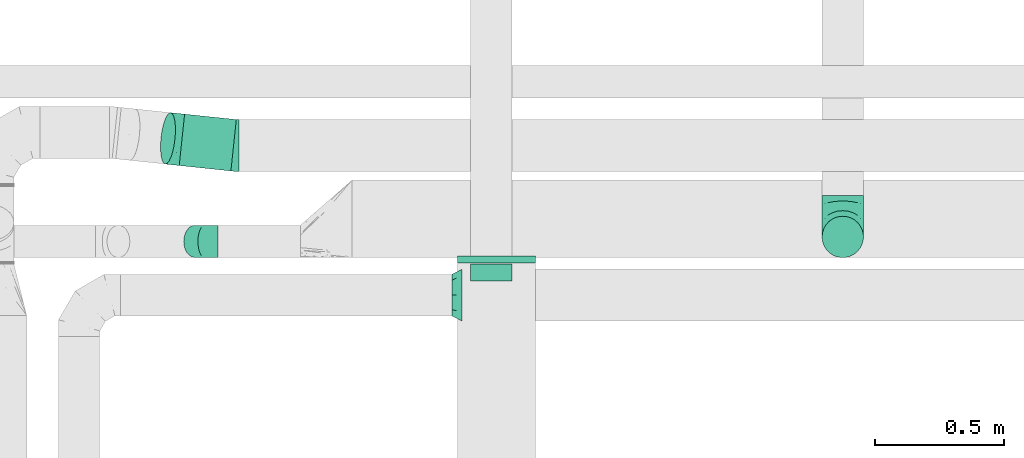
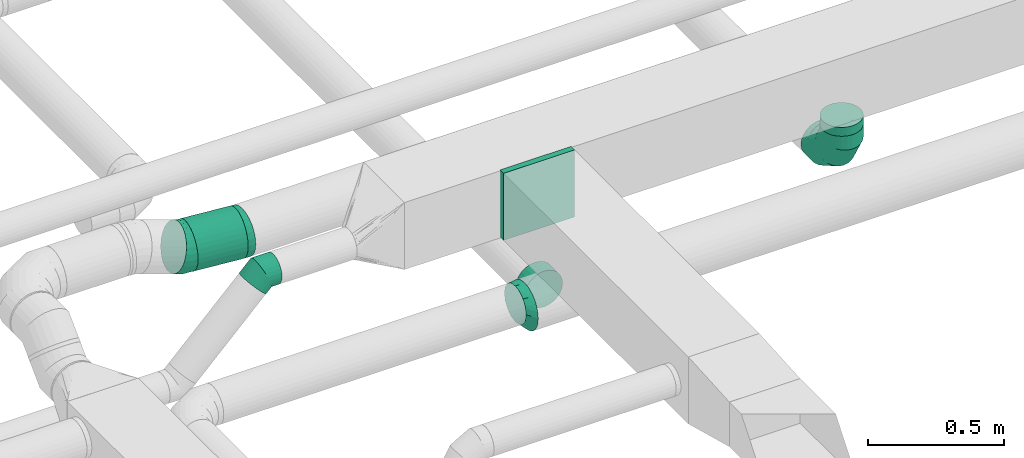
# One storey, part 16 of 60: 7 flow fittings, 2 flow segments.
"""IFC2X3 building model written with IfcOpenShell, lengths in millimetres."""

from ifc_helpers import new_model, entity, si_unit, converted_unit, derived_unit, direction, frame, origin, origin_2d_with_axis, place, context, subcontext, project, spatial, rectangle, circle, extrude, faceted_brep, source, transform, mapped, material, type_object, type_shapes, element, save


model = new_model("IFC2X3")

# Units and contexts
model_context = context("Model", 3, precision=0.01, world=origin(), true_north=direction((6.12303176911189e-17, 1.0)))
body_context = subcontext(model_context, "Body", "Model", "MODEL_VIEW")
ifc_project = project(units=[si_unit("LENGTHUNIT", "METRE", prefix="MILLI"), si_unit("AREAUNIT", "SQUARE_METRE"), si_unit("VOLUMEUNIT", "CUBIC_METRE"), converted_unit("PLANEANGLEUNIT", "DEGREE", entity("IfcRatioMeasure", 0.0174532925199433), si_unit("PLANEANGLEUNIT", "RADIAN"), dimensions=[0, 0, 0, 0, 0, 0, 0]), si_unit("MASSUNIT", "GRAM", prefix="KILO"), derived_unit("MASSDENSITYUNIT", [(si_unit("MASSUNIT", "GRAM", prefix="KILO"), 1), (si_unit("LENGTHUNIT", "METRE"), -3)]), derived_unit("MOMENTOFINERTIAUNIT", [(si_unit("LENGTHUNIT", "METRE"), 4)]), si_unit("TIMEUNIT", "SECOND"), si_unit("FREQUENCYUNIT", "HERTZ"), si_unit("THERMODYNAMICTEMPERATUREUNIT", "DEGREE_CELSIUS"), derived_unit("THERMALTRANSMITTANCEUNIT", [(si_unit("MASSUNIT", "GRAM", prefix="KILO"), 1), (si_unit("THERMODYNAMICTEMPERATUREUNIT", "KELVIN"), -1), (si_unit("TIMEUNIT", "SECOND"), -3)]), derived_unit("VOLUMETRICFLOWRATEUNIT", [(si_unit("LENGTHUNIT", "METRE"), 3), (si_unit("TIMEUNIT", "SECOND"), -1)]), derived_unit("MASSFLOWRATEUNIT", [(si_unit("MASSUNIT", "GRAM", prefix="KILO"), 1), (si_unit("TIMEUNIT", "SECOND"), -1)]), derived_unit("ROTATIONALFREQUENCYUNIT", [(si_unit("TIMEUNIT", "SECOND"), -1)]), si_unit("ELECTRICCURRENTUNIT", "AMPERE"), si_unit("ELECTRICVOLTAGEUNIT", "VOLT"), si_unit("POWERUNIT", "WATT"), si_unit("FORCEUNIT", "NEWTON", prefix="KILO"), si_unit("ILLUMINANCEUNIT", "LUX"), si_unit("LUMINOUSFLUXUNIT", "LUMEN"), si_unit("LUMINOUSINTENSITYUNIT", "CANDELA"), derived_unit("USERDEFINED", [(si_unit("MASSUNIT", "GRAM", prefix="KILO"), -1), (si_unit("LENGTHUNIT", "METRE"), -2), (si_unit("TIMEUNIT", "SECOND"), 3), (si_unit("LUMINOUSFLUXUNIT", "LUMEN"), 1)]), derived_unit("LINEARVELOCITYUNIT", [(si_unit("LENGTHUNIT", "METRE"), 1), (si_unit("TIMEUNIT", "SECOND"), -1)]), si_unit("PRESSUREUNIT", "PASCAL"), derived_unit("USERDEFINED", [(si_unit("LENGTHUNIT", "METRE"), -2), (si_unit("MASSUNIT", "GRAM", prefix="KILO"), 1), (si_unit("TIMEUNIT", "SECOND"), -2)]), derived_unit("LINEARFORCEUNIT", [(si_unit("MASSUNIT", "GRAM", prefix="KILO"), 1), (si_unit("LENGTHUNIT", "METRE"), 1), (si_unit("TIMEUNIT", "SECOND"), -2), (si_unit("LENGTHUNIT", "METRE"), -1)]), derived_unit("PLANARFORCEUNIT", [(si_unit("MASSUNIT", "GRAM", prefix="KILO"), 1), (si_unit("LENGTHUNIT", "METRE"), 1), (si_unit("TIMEUNIT", "SECOND"), -2), (si_unit("LENGTHUNIT", "METRE"), -2)])], contexts=[model_context])

# Site, building, storey
site_placement = place(None, origin())
site = spatial("IfcSite", under=ifc_project, at=site_placement, CompositionType="ELEMENT")
building_placement = place(site_placement, origin())
building = spatial("IfcBuilding", under=site, at=building_placement, CompositionType="ELEMENT")
storey_placement = place(building_placement, frame((0.0, 0.0, 19800.0)))
storey = spatial("IfcBuildingStorey", under=building, at=storey_placement, CompositionType="ELEMENT", Elevation=19800.0)

# Flow segments
duct_segment_type = type_object("IfcDuctSegmentType", PredefinedType="NOTDEFINED")
flow_segment_1_placement = place(storey_placement, frame((17387.86, 9978.45, 3383.4)))
element("IfcFlowSegment", 1, at=flow_segment_1_placement, inside=storey, type_object=duct_segment_type, context=body_context, shape_type="SweptSolid", body=[
    extrude(circle(Radius=100.0, at=origin_2d_with_axis()), frame((12.05, 122.07, 101.6), z_axis=(0.994516576413521, -0.104579057362021, 0.0), x_axis=(0.104579057362021, 0.994516576413521, 0.0)), (0.0, 0.0, 1.0), 200.979366839111),
])
flow_segment_2_placement = place(storey_placement, frame((19873.44, 9643.57, 3359.92)))
element("IfcFlowSegment", 2, at=flow_segment_2_placement, inside=storey, type_object=duct_segment_type, context=body_context, shape_type="SweptSolid", body=[
    extrude(circle(Radius=80.0, at=origin_2d_with_axis()), frame((81.6, 81.6, 0.0), z_axis=(0.0, 0.0, 1.0), x_axis=(-1.0, 0.0, 0.0)), (0.0, 0.0, 1.0), 40.0764985282212),
])

# Flow fittings
ifc_material = material()
duct_fitting_type_1 = type_object("IfcDuctFittingType", PredefinedType="NOTDEFINED", material=ifc_material)
shared_shape_1 = source(origin(), body_context, "Body", "SweptSolid", [
    extrude(rectangle(XDim=26.0960000000005, YDim=300.0, at=origin_2d_with_axis()), frame((6.95, 0.0, -150.0)), (0.0, 0.0, 1.0), 300.0),
])
type_shapes(duct_fitting_type_1, [shared_shape_1])
flow_fitting_1_placement = place(storey_placement, frame((18616.2, 9645.16, 3570.0), z_axis=(0.0, 0.0, -1.0), x_axis=(0.0, -1.0, 0.0)))
element("IfcFlowFitting", 3, at=flow_fitting_1_placement, inside=storey, type_object=duct_fitting_type_1, material=ifc_material, context=body_context, shape_type="MappedRepresentation", body=[
    mapped(shared_shape_1, transform((0.0, 0.0, 0.0), scale=1.0)),
])
duct_fitting_type_2 = type_object("IfcDuctFittingType", PredefinedType="NOTDEFINED", material=ifc_material)
shared_shape_2 = source(origin(), body_context, "Body", "Brep", [
    faceted_brep([(-160.0, 0.0, -80.0), (-160.0, -20.71, -77.27), (-160.0, -40.0, -69.28), (-160.0, -56.57, -56.57), (-160.0, -69.28, -40.0), (-160.0, -77.27, -20.71), (-160.0, -80.0, 0.0), (-160.0, -77.27, 20.71), (-160.0, -69.28, 40.0), (-160.0, -56.57, 56.57), (-160.0, -40.0, 69.28), (-160.0, -20.71, 77.27), (-160.0, 0.0, 80.0), (-160.0, 20.71, 77.27), (-160.0, 40.0, 69.28), (-160.0, 56.57, 56.57), (-160.0, 69.28, 40.0), (-160.0, 77.27, 20.71), (-160.0, 80.0, 0.0), (-160.0, 77.27, -20.71), (-160.0, 69.28, -40.0), (-160.0, 56.57, -56.57), (-160.0, 40.0, -69.28), (-160.0, 20.71, -77.27), (-122.68, 20.71, 77.27), (-127.85, 40.0, 69.28), (-117.13, 0.0, 80.0), (-132.29, 56.57, 56.57), (-137.83, 77.27, 20.71), (-138.56, 80.0, 0.0), (-135.69, 69.28, 40.0), (-135.69, 69.28, -40.0), (-132.29, 56.57, -56.57), (-137.83, 77.27, -20.71), (-122.68, 20.71, -77.27), (-117.13, 0.0, -80.0), (-127.85, 40.0, -69.28), (-111.58, -20.71, -77.27), (-106.41, -40.0, -69.28), (-101.97, -56.57, -56.57), (-98.56, -69.28, -40.0), (-96.42, -77.27, -20.71), (-95.69, -80.0, 0.0), (-96.42, -77.27, 20.71), (-98.56, -69.28, 40.0), (-101.97, -56.57, 56.57), (-106.41, -40.0, 69.28), (-111.58, -20.71, 77.27), (-58.03, 58.03, 77.27), (-72.15, 72.15, 69.28), (-42.87, 42.87, 80.0), (-84.28, 84.28, 56.57), (-93.59, 93.59, 40.0), (-99.44, 99.44, 20.71), (-101.44, 101.44, 0.0), (-99.44, 99.44, -20.71), (-93.59, 93.59, -40.0), (-84.28, 84.28, -56.57), (-58.03, 58.03, -77.27), (-42.87, 42.87, -80.0), (-72.15, 72.15, -69.28), (-27.71, 27.71, -77.27), (-13.59, 13.59, -69.28), (-1.46, 1.46, -56.57), (7.85, -7.85, -40.0), (13.7, -13.7, -20.71), (15.69, -15.69, 0.0), (13.7, -13.7, 20.71), (7.85, -7.85, 40.0), (-1.46, 1.46, 56.57), (-13.59, 13.59, 69.28), (-27.71, 27.71, 77.27), (-20.71, 122.68, 77.27), (-40.0, 127.85, 69.28), (0.0, 117.13, 80.0), (-56.57, 132.29, 56.57), (-69.28, 135.69, 40.0), (-77.27, 137.83, 20.71), (-80.0, 138.56, 0.0), (-77.27, 137.83, -20.71), (-69.28, 135.69, -40.0), (-56.57, 132.29, -56.57), (-20.71, 122.68, -77.27), (0.0, 117.13, -80.0), (-40.0, 127.85, -69.28), (20.71, 111.58, -77.27), (40.0, 106.41, -69.28), (56.57, 101.97, -56.57), (69.28, 98.56, -40.0), (77.27, 96.42, -20.71), (80.0, 95.69, 0.0), (77.27, 96.42, 20.71), (69.28, 98.56, 40.0), (56.57, 101.97, 56.57), (40.0, 106.41, 69.28), (20.71, 111.58, 77.27), (-20.71, 160.0, -77.27), (-40.0, 160.0, -69.28), (-56.57, 160.0, -56.57), (-69.28, 160.0, -40.0), (-77.27, 160.0, -20.71), (-80.0, 160.0, 0.0), (-77.27, 160.0, 20.71), (-69.28, 160.0, 40.0), (-56.57, 160.0, 56.57), (-40.0, 160.0, 69.28), (-20.71, 160.0, 77.27), (0.0, 160.0, 80.0), (20.71, 160.0, 77.27), (40.0, 160.0, 69.28), (56.57, 160.0, 56.57), (69.28, 160.0, 40.0), (77.27, 160.0, 20.71), (80.0, 160.0, 0.0), (77.27, 160.0, -20.71), (69.28, 160.0, -40.0), (56.57, 160.0, -56.57), (40.0, 160.0, -69.28), (20.71, 160.0, -77.27), (0.0, 160.0, -80.0)], [[[0, 1, 2, 3, 4, 5, 6, 7, 8, 9, 10, 11, 12, 13, 14, 15, 16, 17, 18, 19, 20, 21, 22, 23]], [[24, 25, 14, 13]], [[26, 24, 13, 12]], [[14, 25, 27, 15]], [[28, 29, 18, 17]], [[30, 28, 17, 16]], [[15, 27, 30, 16]], [[20, 31, 32, 21]], [[33, 31, 20, 19]], [[18, 29, 33, 19]], [[34, 35, 0, 23]], [[36, 34, 23, 22]], [[32, 36, 22, 21]], [[1, 0, 35, 37]], [[2, 1, 37, 38]], [[3, 2, 38, 39]], [[5, 4, 40, 41]], [[6, 5, 41, 42]], [[39, 40, 4, 3]], [[6, 42, 43, 7]], [[7, 43, 44, 8]], [[8, 44, 45, 9]], [[9, 45, 46, 10]], [[10, 46, 47, 11]], [[26, 12, 11, 47]], [[48, 49, 25, 24]], [[50, 48, 24, 26]], [[27, 25, 49, 51]], [[52, 53, 28, 30]], [[51, 52, 30, 27]], [[29, 28, 53, 54]], [[55, 56, 31, 33]], [[54, 55, 33, 29]], [[32, 31, 56, 57]], [[58, 59, 35, 34]], [[60, 58, 34, 36]], [[57, 60, 36, 32]], [[37, 35, 59, 61]], [[38, 37, 61, 62]], [[39, 38, 62, 63]], [[41, 40, 64, 65]], [[42, 41, 65, 66]], [[63, 64, 40, 39]], [[43, 42, 66, 67]], [[44, 43, 67, 68]], [[68, 69, 45, 44]], [[46, 45, 69, 70]], [[47, 46, 70, 71]], [[26, 47, 71, 50]], [[72, 73, 49, 48]], [[74, 72, 48, 50]], [[51, 49, 73, 75]], [[76, 77, 53, 52]], [[75, 76, 52, 51]], [[54, 53, 77, 78]], [[79, 80, 56, 55]], [[78, 79, 55, 54]], [[57, 56, 80, 81]], [[82, 83, 59, 58]], [[84, 82, 58, 60]], [[81, 84, 60, 57]], [[61, 59, 83, 85]], [[62, 61, 85, 86]], [[63, 62, 86, 87]], [[65, 64, 88, 89]], [[66, 65, 89, 90]], [[87, 88, 64, 63]], [[67, 66, 90, 91]], [[68, 67, 91, 92]], [[92, 93, 69, 68]], [[70, 69, 93, 94]], [[71, 70, 94, 95]], [[50, 71, 95, 74]], [[96, 97, 98, 99, 100, 101, 102, 103, 104, 105, 106, 107, 108, 109, 110, 111, 112, 113, 114, 115, 116, 117, 118, 119]], [[72, 74, 107, 106]], [[73, 72, 106, 105]], [[75, 73, 105, 104]], [[77, 76, 103, 102]], [[78, 77, 102, 101]], [[75, 104, 103, 76]], [[78, 101, 100, 79]], [[79, 100, 99, 80]], [[80, 99, 98, 81]], [[84, 97, 96, 82]], [[82, 96, 119, 83]], [[84, 81, 98, 97]], [[118, 117, 86, 85]], [[119, 118, 85, 83]], [[116, 87, 86, 117]], [[88, 115, 114, 89]], [[89, 114, 113, 90]], [[115, 88, 87, 116]], [[112, 111, 92, 91]], [[113, 112, 91, 90]], [[111, 110, 93, 92]], [[95, 94, 109, 108]], [[74, 95, 108, 107]], [[110, 109, 94, 93]]]),
])
type_shapes(duct_fitting_type_2, [shared_shape_2])
flow_fitting_2_placement = place(storey_placement, frame((19955.04, 9725.16, 3199.92), z_axis=(-1.0, 0.0, 0.0), x_axis=(0.0, -1.0, 0.0)))
element("IfcFlowFitting", 4, at=flow_fitting_2_placement, inside=storey, type_object=duct_fitting_type_2, material=ifc_material, context=body_context, shape_type="MappedRepresentation", body=[
    mapped(shared_shape_2, transform((0.0, 0.0, 0.0), scale=1.0)),
])
duct_fitting_type_3 = type_object("IfcDuctFittingType", PredefinedType="NOTDEFINED", material=ifc_material)
shared_shape_3 = source(origin(), body_context, "Body", "Brep", [
    faceted_brep([(-51.78, 0.0, -62.5), (-51.78, -16.18, -60.37), (-51.78, -31.25, -54.13), (-51.78, -44.19, -44.19), (-51.78, -54.13, -31.25), (-51.78, -60.37, -16.18), (-51.78, -62.5, 0.0), (-51.78, -60.37, 16.18), (-51.78, -54.13, 31.25), (-51.78, -44.19, 44.19), (-51.78, -31.25, 54.13), (-51.78, -16.18, 60.37), (-51.78, 0.0, 62.5), (-51.78, 16.18, 60.37), (-51.78, 31.25, 54.13), (-51.78, 44.19, 44.19), (-51.78, 54.13, 31.25), (-51.78, 60.37, 16.18), (-51.78, 62.5, 0.0), (-51.78, 60.37, -16.18), (-51.78, 54.13, -31.25), (-51.78, 44.19, -44.19), (-51.78, 31.25, -54.13), (-51.78, 16.18, -60.37), (-6.7, 16.18, 60.37), (-12.94, 31.25, 54.13), (0.0, 0.0, 62.5), (-18.31, 44.19, 44.19), (-22.42, 54.13, 31.25), (-25.01, 60.37, 16.18), (-25.89, 62.5, 0.0), (-25.01, 60.37, -16.18), (-22.42, 54.13, -31.25), (-18.31, 44.19, -44.19), (-6.7, 16.18, -60.37), (0.0, 0.0, -62.5), (-12.94, 31.25, -54.13), (6.7, -16.18, -60.37), (12.94, -31.25, -54.13), (18.31, -44.19, -44.19), (22.42, -54.13, -31.25), (25.01, -60.37, -16.18), (25.89, -62.5, 0.0), (25.01, -60.37, 16.18), (22.42, -54.13, 31.25), (18.31, -44.19, 44.19), (12.94, -31.25, 54.13), (6.7, -16.18, 60.37), (25.17, 48.05, 60.37), (14.51, 58.71, 54.13), (36.61, 36.61, 62.5), (5.36, 67.86, 44.19), (-1.66, 74.88, 31.25), (-6.08, 79.3, 16.18), (-7.58, 80.81, 0.0), (-6.08, 79.3, -16.18), (-1.66, 74.88, -31.25), (5.36, 67.86, -44.19), (14.51, 58.71, -54.13), (25.17, 48.05, -60.37), (36.61, 36.61, -62.5), (48.05, 25.17, -60.37), (58.71, 14.51, -54.13), (67.86, 5.36, -44.19), (74.88, -1.66, -31.25), (79.3, -6.08, -16.18), (80.81, -7.58, 0.0), (79.3, -6.08, 16.18), (74.88, -1.66, 31.25), (67.86, 5.36, 44.19), (58.71, 14.51, 54.13), (48.05, 25.17, 60.37)], [[[0, 1, 2, 3, 4, 5, 6, 7, 8, 9, 10, 11, 12, 13, 14, 15, 16, 17, 18, 19, 20, 21, 22, 23]], [[24, 25, 14, 13]], [[26, 24, 13, 12]], [[27, 15, 14, 25]], [[28, 29, 17, 16]], [[28, 16, 15, 27]], [[30, 18, 17, 29]], [[31, 32, 20, 19]], [[30, 31, 19, 18]], [[21, 20, 32, 33]], [[34, 35, 0, 23]], [[36, 34, 23, 22]], [[33, 36, 22, 21]], [[1, 0, 35, 37]], [[2, 1, 37, 38]], [[38, 39, 3, 2]], [[5, 4, 40, 41]], [[6, 5, 41, 42]], [[39, 40, 4, 3]], [[6, 42, 43, 7]], [[7, 43, 44, 8]], [[8, 44, 45, 9]], [[9, 45, 46, 10]], [[10, 46, 47, 11]], [[26, 12, 11, 47]], [[48, 49, 25, 24]], [[50, 48, 24, 26]], [[27, 25, 49, 51]], [[29, 28, 52, 53]], [[30, 29, 53, 54]], [[51, 52, 28, 27]], [[30, 54, 55, 31]], [[31, 55, 56, 32]], [[57, 33, 32, 56]], [[36, 58, 59, 34]], [[34, 59, 60, 35]], [[58, 36, 33, 57]], [[35, 60, 61, 37]], [[37, 61, 62, 38]], [[63, 39, 38, 62]], [[40, 64, 65, 41]], [[41, 65, 66, 42]], [[64, 40, 39, 63]], [[43, 42, 66, 67]], [[44, 43, 67, 68]], [[68, 69, 45, 44]], [[47, 46, 70, 71]], [[26, 47, 71, 50]], [[69, 70, 46, 45]], [[59, 58, 57, 56, 55, 54, 53, 52, 51, 49, 48, 50, 71, 70, 69, 68, 67, 66, 65, 64, 63, 62, 61, 60]]]),
])
type_shapes(duct_fitting_type_3, [shared_shape_3])
flow_fitting_3_placement = place(storey_placement, frame((17487.7, 9707.66, 3569.92), z_axis=(0.0, 1.0, 0.0), x_axis=(0.707106781186554, 0.0, 0.707106781186541)))
element("IfcFlowFitting", 5, at=flow_fitting_3_placement, inside=storey, type_object=duct_fitting_type_3, material=ifc_material, context=body_context, shape_type="MappedRepresentation", body=[
    mapped(shared_shape_3, transform((0.0, 0.0, 0.0), scale=1.0)),
])
duct_fitting_type_4 = type_object("IfcDuctFittingType", PredefinedType="NOTDEFINED", material=ifc_material)
shared_shape_4 = source(origin(), body_context, "Body", "Brep", [
    faceted_brep([(20.0, 0.0, -80.0), (20.0, 20.71, -77.27), (20.0, 40.0, -69.28), (20.0, 56.57, -56.57), (20.0, 69.28, -40.0), (20.0, 77.27, -20.71), (20.0, 80.0, 0.0), (20.0, 77.27, 20.71), (20.0, 69.28, 40.0), (20.0, 56.57, 56.57), (20.0, 40.0, 69.28), (20.0, 20.71, 77.27), (20.0, 0.0, 80.0), (20.0, -20.71, 77.27), (20.0, -40.0, 69.28), (20.0, -56.57, 56.57), (20.0, -69.28, 40.0), (20.0, -77.27, 20.71), (20.0, -80.0, 0.0), (20.0, -77.27, -20.71), (20.0, -69.28, -40.0), (20.0, -56.57, -56.57), (20.0, -40.0, -69.28), (20.0, -20.71, -77.27), (0.0, 0.0, 80.0), (-46.1, 0.0, 80.0), (-46.1, -20.71, 77.27), (0.0, -20.71, 77.27), (-46.1, -40.0, 69.28), (0.0, -40.0, 69.28), (0.0, -56.57, 56.57), (-46.1, -56.57, 56.57), (0.0, -69.28, 40.0), (-46.1, -69.28, 40.0), (-46.1, -77.27, 20.71), (0.0, -77.27, 20.71), (-46.1, -80.0, 0.0), (0.0, -80.0, 0.0), (-46.1, -77.27, -20.71), (0.0, -77.27, -20.71), (-46.1, -69.28, -40.0), (0.0, -69.28, -40.0), (0.0, -56.57, -56.57), (-46.1, -56.57, -56.57), (0.0, -40.0, -69.28), (-46.1, -40.0, -69.28), (-46.1, -20.71, -77.27), (0.0, -20.71, -77.27), (-46.1, 0.0, -80.0), (0.0, 0.0, -80.0), (-46.1, 20.71, -77.27), (0.0, 20.71, -77.27), (-46.1, 40.0, -69.28), (0.0, 40.0, -69.28), (0.0, 56.57, -56.57), (-46.1, 56.57, -56.57), (0.0, 69.28, -40.0), (-46.1, 69.28, -40.0), (-46.1, 77.27, -20.71), (0.0, 77.27, -20.71), (-46.1, 80.0, 0.0), (0.0, 80.0, 0.0), (-46.1, 77.27, 20.71), (0.0, 77.27, 20.71), (-46.1, 69.28, 40.0), (0.0, 69.28, 40.0), (0.0, 56.57, 56.57), (-46.1, 56.57, 56.57), (0.0, 40.0, 69.28), (-46.1, 40.0, 69.28), (-46.1, 20.71, 77.27), (0.0, 20.71, 77.27)], [[[0, 1, 2, 3, 4, 5, 6, 7, 8, 9, 10, 11, 12, 13, 14, 15, 16, 17, 18, 19, 20, 21, 22, 23]], [[13, 12, 24, 25, 26, 27]], [[14, 13, 27, 26, 28, 29]], [[30, 15, 14, 29, 28, 31]], [[17, 16, 32, 33, 34, 35]], [[18, 17, 35, 34, 36, 37]], [[32, 16, 15, 30, 31, 33]], [[19, 18, 37, 36, 38, 39]], [[20, 19, 39, 38, 40, 41]], [[42, 21, 20, 41, 40, 43]], [[23, 22, 44, 45, 46, 47]], [[0, 23, 47, 46, 48, 49]], [[44, 22, 21, 42, 43, 45]], [[1, 0, 49, 48, 50, 51]], [[2, 1, 51, 50, 52, 53]], [[54, 3, 2, 53, 52, 55]], [[5, 4, 56, 57, 58, 59]], [[6, 5, 59, 58, 60, 61]], [[56, 4, 3, 54, 55, 57]], [[7, 6, 61, 60, 62, 63]], [[8, 7, 63, 62, 64, 65]], [[66, 9, 8, 65, 64, 67]], [[11, 10, 68, 69, 70, 71]], [[12, 11, 71, 70, 25, 24]], [[68, 10, 9, 66, 67, 69]], [[46, 45, 43, 40, 38, 36, 34, 33, 31, 28, 26, 25, 70, 69, 67, 64, 62, 60, 58, 57, 55, 52, 50, 48]]]),
])
type_shapes(duct_fitting_type_4, [shared_shape_4])
flow_fitting_4_placement = place(storey_placement, frame((18595.33, 9600.18, 3200.0), z_axis=(0.0, 0.0, -1.0), x_axis=(0.0, 1.0, 0.0)))
element("IfcFlowFitting", 6, at=flow_fitting_4_placement, inside=storey, type_object=duct_fitting_type_4, material=ifc_material, context=body_context, shape_type="MappedRepresentation", body=[
    mapped(shared_shape_4, transform((0.0, 0.0, 0.0), scale=1.0)),
])
duct_fitting_type_5 = type_object("IfcDuctFittingType", PredefinedType="NOTDEFINED", material=ifc_material)
shared_shape_5 = source(origin(), body_context, "Body", "Brep", [
    faceted_brep([(40.0, -58.78, -100.9), (40.0, -30.9, -115.11), (40.0, 0.0, -120.0), (40.0, 30.9, -115.11), (40.0, 58.78, -100.9), (40.0, 80.9, -78.78), (40.0, 95.11, -50.9), (40.0, 100.0, -20.0), (40.0, 95.11, 10.9), (40.0, 80.9, 38.78), (40.0, 58.78, 60.9), (40.0, 30.9, 75.11), (40.0, 0.0, 80.0), (40.0, -30.9, 75.11), (40.0, -58.78, 60.9), (40.0, -80.9, 38.78), (40.0, -95.11, 10.9), (40.0, -100.0, -20.0), (40.0, -95.11, -50.9), (40.0, -80.9, -78.78), (0.0, -56.57, -56.57), (0.0, -65.24, -43.59), (0.0, -73.91, -30.61), (0.0, -76.96, -15.31), (0.0, -80.0, 0.0), (0.0, -76.96, 15.31), (0.0, -73.91, 30.61), (0.0, -65.24, 43.59), (0.0, -56.57, 56.57), (0.0, -43.59, 65.24), (0.0, -30.61, 73.91), (0.0, -15.31, 76.96), (0.0, 0.0, 80.0), (0.0, 15.31, 76.96), (0.0, 30.61, 73.91), (0.0, 43.59, 65.24), (0.0, 56.57, 56.57), (0.0, 65.24, 43.59), (0.0, 73.91, 30.61), (0.0, 76.96, 15.31), (0.0, 80.0, 0.0), (0.0, 76.96, -15.31), (0.0, 73.91, -30.61), (0.0, 65.24, -43.59), (0.0, 56.57, -56.57), (0.0, 43.59, -65.24), (0.0, 30.61, -73.91), (0.0, 15.31, -76.96), (0.0, 0.0, -80.0), (0.0, -15.31, -76.96), (0.0, -30.61, -73.91), (0.0, -43.59, -65.24), (18.77, 85.54, 16.56), (20.0, 90.0, -10.0), (18.17, 89.08, -9.08), (19.3, 77.72, 35.03), (21.23, 42.72, 69.3), (21.05, 67.33, 49.98), (18.5, 24.79, 76.49), (18.17, 0.0, 80.0), (20.0, 0.0, 80.0), (18.77, -25.95, 76.15), (19.3, -44.68, 68.07), (21.23, -79.92, 32.1), (21.05, -60.51, 56.81), (18.5, -85.74, 15.55), (16.11, -88.06, -8.06), (20.0, -90.0, -10.0), (18.77, -85.54, -35.33), (19.3, -77.72, -54.33), (21.05, -67.33, -71.03), (18.5, -24.79, -94.98), (21.23, -42.72, -90.53), (16.11, 0.0, -96.11), (20.0, 0.0, -100.0), (18.77, 25.95, -94.92), (19.3, 44.68, -87.37), (21.05, 60.51, -77.86), (18.5, 85.74, -34.04), (21.23, 79.92, -53.33)], [[[0, 1, 2, 3, 4, 5, 6, 7, 8, 9, 10, 11, 12, 13, 14, 15, 16, 17, 18, 19]], [[20, 21, 22, 23, 24, 25, 26, 27, 28, 29, 30, 31, 32, 33, 34, 35, 36, 37, 38, 39, 40, 41, 42, 43, 44, 45, 46, 47, 48, 49, 50, 51]], [[52, 7, 53, 54]], [[39, 38, 52]], [[52, 38, 55]], [[54, 39, 52]], [[52, 55, 8]], [[54, 40, 39]], [[9, 8, 55]], [[34, 56, 35]], [[35, 57, 36]], [[52, 8, 7]], [[37, 57, 55]], [[56, 58, 11]], [[57, 56, 10]], [[12, 11, 58]], [[35, 56, 57]], [[57, 37, 36]], [[58, 56, 34]], [[57, 9, 55]], [[11, 10, 56]], [[10, 9, 57]], [[58, 34, 33]], [[33, 32, 59, 60]], [[55, 38, 37]], [[60, 12, 58]], [[33, 60, 58]], [[61, 12, 60, 59]], [[31, 30, 61]], [[61, 30, 62]], [[59, 31, 61]], [[61, 62, 13]], [[59, 32, 31]], [[14, 13, 62]], [[26, 63, 27]], [[27, 64, 28]], [[61, 13, 12]], [[29, 64, 62]], [[63, 65, 16]], [[64, 63, 15]], [[17, 16, 65]], [[27, 63, 64]], [[64, 29, 28]], [[65, 63, 26]], [[64, 14, 62]], [[16, 15, 63]], [[15, 14, 64]], [[65, 26, 25]], [[25, 24, 66, 67]], [[62, 30, 29]], [[67, 17, 65]], [[25, 67, 65]], [[68, 17, 67, 66]], [[66, 24, 23]], [[68, 22, 69]], [[66, 23, 68]], [[68, 69, 18]], [[23, 22, 68]], [[19, 18, 69]], [[21, 70, 69]], [[51, 70, 20]], [[70, 21, 20]], [[71, 72, 50]], [[72, 71, 1]], [[70, 72, 0]], [[2, 1, 71]], [[0, 19, 70]], [[68, 18, 17]], [[51, 72, 70]], [[70, 19, 69]], [[1, 0, 72]], [[50, 72, 51]], [[71, 50, 49]], [[49, 48, 73, 74]], [[69, 22, 21]], [[74, 2, 71]], [[49, 74, 71]], [[75, 2, 74, 73]], [[73, 48, 47]], [[75, 46, 76]], [[73, 47, 75]], [[75, 76, 3]], [[47, 46, 75]], [[4, 3, 76]], [[45, 77, 76]], [[43, 77, 44]], [[77, 45, 44]], [[78, 79, 42]], [[79, 78, 6]], [[77, 79, 5]], [[7, 6, 78]], [[5, 4, 77]], [[75, 3, 2]], [[43, 79, 77]], [[77, 4, 76]], [[6, 5, 79]], [[42, 79, 43]], [[78, 42, 41]], [[41, 40, 54, 53]], [[76, 46, 45]], [[53, 7, 78]], [[41, 53, 78]]]),
])
type_shapes(duct_fitting_type_5, [shared_shape_5])
flow_fitting_5_placement = place(storey_placement, frame((18443.27, 9500.18, 3220.0)))
element("IfcFlowFitting", 7, at=flow_fitting_5_placement, inside=storey, type_object=duct_fitting_type_5, material=ifc_material, context=body_context, shape_type="MappedRepresentation", body=[
    mapped(shared_shape_5, transform((0.0, 0.0, 0.0), scale=1.0)),
])
duct_fitting_type_6 = type_object("IfcDuctFittingType", PredefinedType="NOTDEFINED", material=ifc_material)
shared_shape_6 = source(origin(), body_context, "Body", "Brep", [
    faceted_brep([(-10.49, 0.0, -100.0), (-10.49, -25.88, -96.59), (-10.49, -50.0, -86.6), (-10.49, -70.71, -70.71), (-10.49, -86.6, -50.0), (-10.49, -96.59, -25.88), (-10.49, -100.0, 0.0), (-10.49, -96.59, 25.88), (-10.49, -86.6, 50.0), (-10.49, -70.71, 70.71), (-10.49, -50.0, 86.6), (-10.49, -25.88, 96.59), (-10.49, 0.0, 100.0), (-10.49, 25.88, 96.59), (-10.49, 50.0, 86.6), (-10.49, 70.71, 70.71), (-10.49, 86.6, 50.0), (-10.49, 96.59, 25.88), (-10.49, 100.0, 0.0), (-10.49, 96.59, -25.88), (-10.49, 86.6, -50.0), (-10.49, 70.71, -70.71), (-10.49, 50.0, -86.6), (-10.49, 25.88, -96.59), (-1.36, 25.88, 96.59), (-2.62, 50.0, 86.6), (0.0, 0.0, 100.0), (-3.71, 70.71, 70.71), (-5.06, 96.59, 25.88), (-5.24, 100.0, 0.0), (-4.54, 86.6, 50.0), (-4.54, 86.6, -50.0), (-3.71, 70.71, -70.71), (-5.06, 96.59, -25.88), (-1.36, 25.88, -96.59), (0.0, 0.0, -100.0), (-2.62, 50.0, -86.6), (1.36, -25.88, -96.59), (2.62, -50.0, -86.6), (3.71, -70.71, -70.71), (4.54, -86.6, -50.0), (5.06, -96.59, -25.88), (5.24, -100.0, 0.0), (5.06, -96.59, 25.88), (4.54, -86.6, 50.0), (3.71, -70.71, 70.71), (2.62, -50.0, 86.6), (1.36, -25.88, 96.59), (10.43, 1.1, 100.0), (7.72, 26.84, 96.59), (5.2, 50.82, 86.6), (3.03, 71.42, 70.71), (1.37, 87.22, 50.0), (0.33, 97.16, 25.88), (-0.03, 100.55, 0.0), (0.33, 97.16, -25.88), (1.37, 87.22, -50.0), (3.03, 71.42, -70.71), (5.2, 50.82, -86.6), (7.72, 26.84, -96.59), (10.43, 1.1, -100.0), (13.14, -24.64, -96.59), (15.66, -48.63, -86.6), (17.82, -69.23, -70.71), (19.49, -85.03, -50.0), (20.53, -94.97, -25.88), (20.89, -98.35, 0.0), (20.53, -94.97, 25.88), (19.49, -85.03, 50.0), (17.82, -69.23, 70.71), (15.66, -48.63, 86.6), (13.14, -24.64, 96.59)], [[[0, 1, 2, 3, 4, 5, 6, 7, 8, 9, 10, 11, 12, 13, 14, 15, 16, 17, 18, 19, 20, 21, 22, 23]], [[24, 25, 14, 13]], [[26, 24, 13, 12]], [[14, 25, 27, 15]], [[28, 29, 18, 17]], [[30, 28, 17, 16]], [[15, 27, 30, 16]], [[20, 31, 32, 21]], [[33, 31, 20, 19]], [[18, 29, 33, 19]], [[34, 35, 0, 23]], [[36, 34, 23, 22]], [[32, 36, 22, 21]], [[2, 1, 37, 38]], [[3, 2, 38, 39]], [[0, 35, 37, 1]], [[5, 4, 40, 41]], [[6, 5, 41, 42]], [[39, 40, 4, 3]], [[6, 42, 43, 7]], [[7, 43, 44, 8]], [[8, 44, 45, 9]], [[10, 46, 47, 11]], [[11, 47, 26, 12]], [[9, 45, 46, 10]], [[24, 26, 48, 49]], [[25, 24, 49, 50]], [[27, 25, 50, 51]], [[28, 30, 52, 53]], [[29, 28, 53, 54]], [[27, 51, 52, 30]], [[29, 54, 55, 33]], [[33, 55, 56, 31]], [[31, 56, 57, 32]], [[36, 58, 59, 34]], [[34, 59, 60, 35]], [[36, 32, 57, 58]], [[35, 60, 61, 37]], [[37, 61, 62, 38]], [[38, 62, 63, 39]], [[40, 64, 65, 41]], [[41, 65, 66, 42]], [[39, 63, 64, 40]], [[43, 42, 66, 67]], [[44, 43, 67, 68]], [[45, 44, 68, 69]], [[47, 46, 70, 71]], [[26, 47, 71, 48]], [[69, 70, 46, 45]], [[59, 58, 57, 56, 55, 54, 53, 52, 51, 50, 49, 48, 71, 70, 69, 68, 67, 66, 65, 64, 63, 62, 61, 60]]]),
])
type_shapes(duct_fitting_type_6, [shared_shape_6])
flow_fitting_6_placement = place(storey_placement, frame((17610.22, 10078.4, 3485.0), z_axis=(0.0, 0.0, 1.0), x_axis=(0.994516576413524, -0.104579057361993, 0.0)))
element("IfcFlowFitting", 8, at=flow_fitting_6_placement, inside=storey, type_object=duct_fitting_type_6, material=ifc_material, context=body_context, shape_type="MappedRepresentation", body=[
    mapped(shared_shape_6, transform((0.0, 0.0, 0.0), scale=1.0)),
])
duct_fitting_type_7 = type_object("IfcDuctFittingType", PredefinedType="NOTDEFINED", material=ifc_material)
shared_shape_7 = source(origin(), body_context, "Body", "Brep", [
    faceted_brep([(-27.58, 0.0, -100.0), (-27.58, -25.88, -96.59), (-27.58, -50.0, -86.6), (-27.58, -70.71, -70.71), (-27.58, -86.6, -50.0), (-27.58, -96.59, -25.88), (-27.58, -100.0, 0.0), (-27.58, -96.59, 25.88), (-27.58, -86.6, 50.0), (-27.58, -70.71, 70.71), (-27.58, -50.0, 86.6), (-27.58, -25.88, 96.59), (-27.58, 0.0, 100.0), (-27.58, 25.88, 96.59), (-27.58, 50.0, 86.6), (-27.58, 70.71, 70.71), (-27.58, 86.6, 50.0), (-27.58, 96.59, 25.88), (-27.58, 100.0, 0.0), (-27.58, 96.59, -25.88), (-27.58, 86.6, -50.0), (-27.58, 70.71, -70.71), (-27.58, 50.0, -86.6), (-27.58, 25.88, -96.59), (-3.57, 25.88, 96.59), (-6.9, 50.0, 86.6), (0.0, 0.0, 100.0), (-9.75, 70.71, 70.71), (-13.32, 96.59, 25.88), (-13.79, 100.0, 0.0), (-11.94, 86.6, 50.0), (-11.94, 86.6, -50.0), (-9.75, 70.71, -70.71), (-13.32, 96.59, -25.88), (-3.57, 25.88, -96.59), (0.0, 0.0, -100.0), (-6.9, 50.0, -86.6), (3.57, -25.88, -96.59), (6.9, -50.0, -86.6), (9.75, -70.71, -70.71), (11.94, -86.6, -50.0), (13.32, -96.59, -25.88), (13.79, -100.0, 0.0), (13.32, -96.59, 25.88), (11.94, -86.6, 50.0), (9.75, -70.71, 70.71), (6.9, -50.0, 86.6), (3.57, -25.88, 96.59), (26.55, 7.47, 100.0), (19.55, 32.38, 96.59), (13.02, 55.6, 86.6), (7.41, 75.54, 70.71), (3.11, 90.84, 50.0), (0.41, 100.45, 25.88), (-0.51, 103.73, 0.0), (0.41, 100.45, -25.88), (3.11, 90.84, -50.0), (7.41, 75.54, -70.71), (13.02, 55.6, -86.6), (19.55, 32.38, -96.59), (26.55, 7.47, -100.0), (33.56, -17.45, -96.59), (40.09, -40.67, -86.6), (45.69, -60.6, -70.71), (50.0, -75.9, -50.0), (52.7, -85.52, -25.88), (53.62, -88.8, 0.0), (52.7, -85.52, 25.88), (50.0, -75.9, 50.0), (45.69, -60.6, 70.71), (40.09, -40.67, 86.6), (33.56, -17.45, 96.59)], [[[0, 1, 2, 3, 4, 5, 6, 7, 8, 9, 10, 11, 12, 13, 14, 15, 16, 17, 18, 19, 20, 21, 22, 23]], [[24, 25, 14, 13]], [[26, 24, 13, 12]], [[14, 25, 27, 15]], [[28, 29, 18, 17]], [[30, 28, 17, 16]], [[15, 27, 30, 16]], [[20, 31, 32, 21]], [[33, 31, 20, 19]], [[18, 29, 33, 19]], [[34, 35, 0, 23]], [[36, 34, 23, 22]], [[32, 36, 22, 21]], [[2, 1, 37, 38]], [[3, 2, 38, 39]], [[0, 35, 37, 1]], [[5, 4, 40, 41]], [[6, 5, 41, 42]], [[39, 40, 4, 3]], [[6, 42, 43, 7]], [[7, 43, 44, 8]], [[8, 44, 45, 9]], [[10, 46, 47, 11]], [[11, 47, 26, 12]], [[9, 45, 46, 10]], [[24, 26, 48, 49]], [[25, 24, 49, 50]], [[27, 25, 50, 51]], [[28, 30, 52, 53]], [[29, 28, 53, 54]], [[27, 51, 52, 30]], [[29, 54, 55, 33]], [[33, 55, 56, 31]], [[31, 56, 57, 32]], [[36, 58, 59, 34]], [[34, 59, 60, 35]], [[36, 32, 57, 58]], [[35, 60, 61, 37]], [[37, 61, 62, 38]], [[38, 62, 63, 39]], [[40, 64, 65, 41]], [[41, 65, 66, 42]], [[39, 63, 64, 40]], [[43, 42, 66, 67]], [[44, 43, 67, 68]], [[45, 44, 68, 69]], [[47, 46, 70, 71]], [[26, 47, 71, 48]], [[69, 70, 46, 45]], [[59, 58, 57, 56, 55, 54, 53, 52, 51, 50, 49, 48, 71, 70, 69, 68, 67, 66, 65, 64, 63, 62, 61, 60]]]),
])
type_shapes(duct_fitting_type_7, [shared_shape_7])
flow_fitting_7_placement = place(storey_placement, frame((17372.48, 10103.4, 3485.0), z_axis=(0.104579057362035, 0.99451657641352, 0.0), x_axis=(-0.99451657641352, 0.104579057362035, 0.0)))
element("IfcFlowFitting", 9, at=flow_fitting_7_placement, inside=storey, type_object=duct_fitting_type_7, material=ifc_material, context=body_context, shape_type="MappedRepresentation", body=[
    mapped(shared_shape_7, transform((0.0, 0.0, 0.0), scale=1.0)),
])

save(model, "model.ifc")
